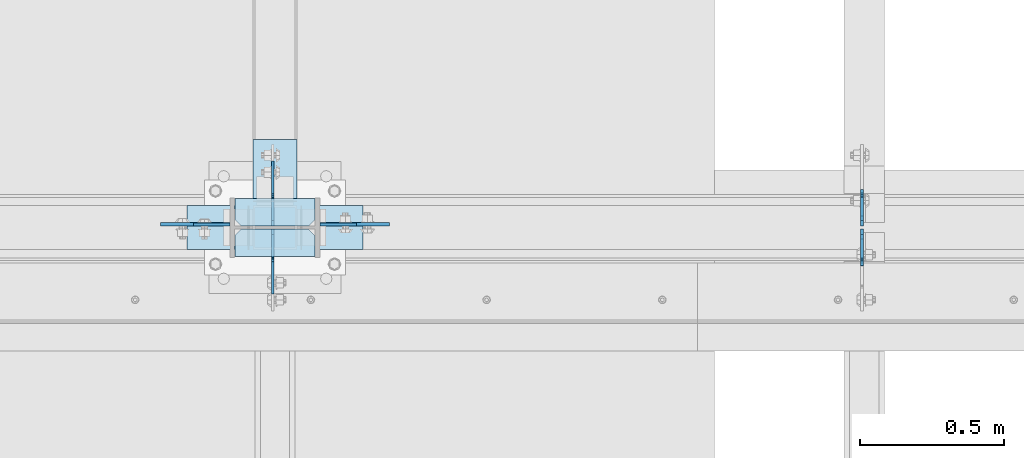
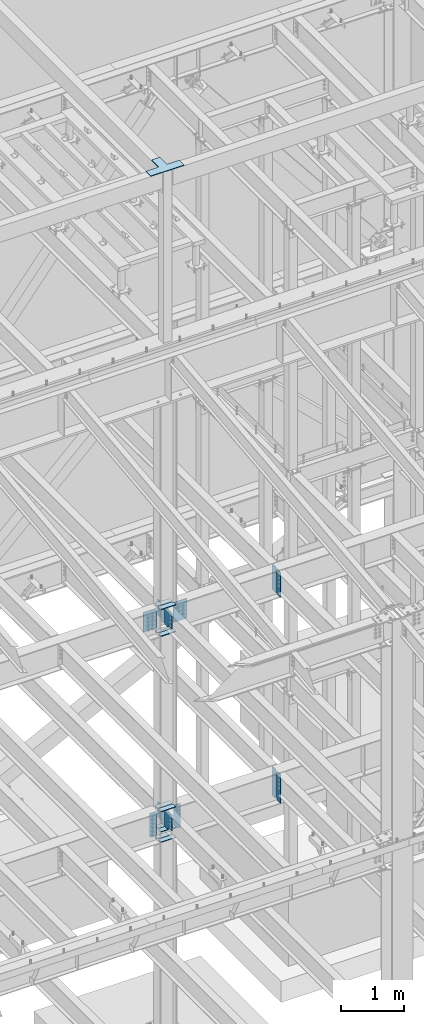
# One storey, part 1064 of 1179: 23 plates, 4 elements without a shape of their own.
"""IFC2X3 building model written with IfcOpenShell, lengths in millimetres."""

from ifc_helpers import new_model, si_unit, frame, origin_with_axes, place, context, subcontext, project, spatial, faceted_brep, material, type_object, element, aggregate, save


model = new_model("IFC2X3")

# Units and contexts
model_context = context("Model", 3, precision=1e-05, world=origin_with_axes())
body_context = subcontext(model_context, "Body", "Model", "MODEL_VIEW")
ifc_project = project(units=[si_unit("LENGTHUNIT", "METRE", prefix="MILLI"), si_unit("AREAUNIT", "SQUARE_METRE"), si_unit("VOLUMEUNIT", "CUBIC_METRE"), si_unit("MASSUNIT", "GRAM", prefix="KILO"), si_unit("TIMEUNIT", "SECOND"), si_unit("PLANEANGLEUNIT", "RADIAN"), si_unit("SOLIDANGLEUNIT", "STERADIAN"), si_unit("THERMODYNAMICTEMPERATUREUNIT", "DEGREE_CELSIUS"), si_unit("LUMINOUSINTENSITYUNIT", "LUMEN")], contexts=[model_context])

# Site, building, storey
site_placement = place(None, origin_with_axes())
site = spatial("IfcSite", under=ifc_project, at=site_placement, CompositionType="ELEMENT")
building_placement = place(site_placement, origin_with_axes())
building = spatial("IfcBuilding", under=site, at=building_placement, Name="Undefined", CompositionType="ELEMENT")
storey_placement = place(building_placement, origin_with_axes())
storey = spatial("IfcBuildingStorey", under=building, at=storey_placement, Name="Undefined", CompositionType="ELEMENT", Elevation=0.0)

# Assembly, plates
assembly_1_placement = place(storey_placement, origin_with_axes())
assembly_1 = element("IfcElementAssembly", 1, at=assembly_1_placement, inside=storey, Name="BEAM", AssemblyPlace="NOTDEFINED", PredefinedType="RIGID_FRAME")
ifc_material_1 = material(Name="STEEL/A36")
plate_type_1 = type_object("IfcPlateType", PredefinedType="NOTDEFINED")
plate_1_placement = place(assembly_1_placement, frame((10317.1620000839, 34396.3625, 7497.7625), z_axis=(0.0, 0.0, 1.0), x_axis=(0.0, 1.0, 0.0)))
plate_1 = element("IfcPlate", 2, at=plate_1_placement, type_object=plate_type_1, material=ifc_material_1, Name="PLATE", context=body_context, shape_type="Brep", body=[
    faceted_brep([(100.012500000004, -4.76250000000073, 498.475), (100.012500000004, -4.76250000000073, 493.712499809265), (100.012500000004, 4.76250000000073, 493.712499809265), (100.012500000004, 4.76250000000073, 498.475), (100.979229922596, -4.76250000000073, 488.852420291219), (100.979229922596, 4.76250000000073, 488.852420291219), (103.732243823069, -4.76250000000073, 484.732243823066), (103.732243823069, 4.76250000000073, 484.732243823066), (107.852420291223, -4.76250000000073, 481.979229922587), (107.852420291223, 4.76250000000073, 481.979229922587), (112.71249980927, -4.76250000000073, 481.0125), (112.71249980927, 4.76250000000073, 481.0125), (127.000007629395, -4.76250000000073, 481.0125), (127.0, 4.76250000000073, 481.0125), (0.0, -4.76250000000073, 479.425006866455), (19.0499992370605, -4.76250000000073, 498.475006103516), (19.0499992370605, 4.76250000000073, 498.475006103516), (0.0, 4.76250000000073, 479.425006866455), (0.0, -4.76250000000073, 19.0499992370605), (0.0, 4.76250000000073, 19.0499992370605), (19.0499992370605, -4.76250000000073, 0.0), (19.0499992370605, 4.76250000000073, 0.0), (127.0, -4.76250000000073, 0.0), (127.0, 4.76250000000073, 0.0)], [[[0, 1, 2, 3]], [[4, 5, 2, 1]], [[6, 7, 5, 4]], [[8, 9, 7, 6]], [[10, 11, 9, 8]], [[12, 13, 11, 10]], [[14, 15, 16, 17]], [[18, 14, 17, 19]], [[20, 18, 19, 21]], [[22, 20, 21, 23]], [[8, 6, 4, 1, 0, 15, 14, 18, 20, 22, 12, 10]], [[16, 15, 0, 3]], [[23, 21, 19, 17, 16, 3, 2, 5, 7, 9, 11, 13]], [[22, 23, 13, 12]]]),
])
plate_2_placement = place(assembly_1_placement, frame((10317.1620000839, 34386.8375, 7497.7625), z_axis=(0.0, 0.0, 1.0), x_axis=(0.0, -1.0, 0.0)))
plate_2 = element("IfcPlate", 3, at=plate_2_placement, type_object=plate_type_1, material=ifc_material_1, Name="PLATE", context=body_context, shape_type="Brep", body=[
    faceted_brep([(100.012500000004, -4.76250000000073, 498.475), (100.012500000004, -4.76250000000073, 493.712499809265), (100.012500000004, 4.76250000000073, 493.712499809265), (100.012500000004, 4.76250000000073, 498.475), (100.979229922596, -4.76250000000073, 488.852420291219), (100.979229922596, 4.76250000000073, 488.852420291219), (103.732243823069, -4.76250000000073, 484.732243823066), (103.732243823069, 4.76250000000073, 484.732243823066), (107.852420291223, -4.76250000000073, 481.979229922587), (107.852420291223, 4.76250000000073, 481.979229922587), (112.71249980927, -4.76250000000073, 481.0125), (112.71249980927, 4.76250000000073, 481.0125), (127.000007629395, -4.76250000000073, 481.0125), (127.0, 4.76250000000073, 481.0125), (0.0, -4.76250000000073, 479.425006866455), (19.0499992370605, -4.76250000000073, 498.475006103516), (19.0499992370605, 4.76250000000073, 498.475006103516), (0.0, 4.76250000000073, 479.425006866455), (0.0, -4.76250000000073, 19.0499992370605), (0.0, 4.76250000000073, 19.0499992370605), (19.0499992370605, -4.76250000000073, 0.0), (19.0499992370605, 4.76250000000073, 0.0), (127.0, -4.76250000000073, 0.0), (127.0, 4.76250000000073, 0.0)], [[[0, 1, 2, 3]], [[4, 5, 2, 1]], [[6, 7, 5, 4]], [[8, 9, 7, 6]], [[10, 11, 9, 8]], [[12, 13, 11, 10]], [[14, 15, 16, 17]], [[18, 14, 17, 19]], [[20, 18, 19, 21]], [[22, 20, 21, 23]], [[8, 6, 4, 1, 0, 15, 14, 18, 20, 22, 12, 10]], [[16, 15, 0, 3]], [[23, 21, 19, 17, 16, 3, 2, 5, 7, 9, 11, 13]], [[22, 23, 13, 12]]]),
])
aggregate(assembly_1, [plate_1, plate_2])

assembly_2_placement = place(storey_placement, origin_with_axes())
assembly_2 = element("IfcElementAssembly", 4, at=assembly_2_placement, inside=storey, Name="COLUMN", AssemblyPlace="NOTDEFINED", PredefinedType="RIGID_FRAME")
plate_3_placement = place(assembly_2_placement, frame((8435.975, 34401.91875, 4051.3), z_axis=(1.0, 0.0, 0.0), x_axis=(0.0, 0.0, -1.0)))
plate_3 = element("IfcPlate", 5, at=plate_3_placement, type_object=plate_type_1, material=ifc_material_1, Name="PLATE", context=body_context, shape_type="Brep", body=[
    faceted_brep([(0.0, -4.76249999999709, 0.0), (0.0, -4.76249999999709, 127.0), (0.0, 4.76249999999709, 127.0), (0.0, 4.76249999999709, 0.0), (457.200012207031, -4.76250000000073, 127.0), (457.200012207031, 4.76250000000073, 127.0), (457.200012207031, -4.76250000000073, 0.0), (457.200012207031, 4.76250000000073, 0.0)], [[[0, 1, 2, 3]], [[1, 4, 5, 2]], [[4, 6, 7, 5]], [[6, 0, 3, 7]], [[5, 7, 3, 2]], [[6, 4, 1, 0]]]),
])
plate_4_placement = place(assembly_2_placement, frame((8124.825, 34401.91875, 4051.3), z_axis=(-1.0, 0.0, 0.0), x_axis=(0.0, 0.0, -1.0)))
plate_4 = element("IfcPlate", 6, at=plate_4_placement, type_object=plate_type_1, material=ifc_material_1, Name="PLATE", context=body_context, shape_type="Brep", body=[
    faceted_brep([(0.0, -4.76249999999709, 0.0), (0.0, -4.76249999999709, 127.0), (0.0, 4.76249999999709, 127.0), (0.0, 4.76249999999709, 0.0), (457.200012207031, -4.76250000000073, 127.0), (457.200012207031, 4.76250000000073, 127.0), (457.200012207031, -4.76250000000073, 0.0), (457.200012207031, 4.76250000000073, 0.0)], [[[0, 1, 2, 3]], [[1, 4, 5, 2]], [[4, 6, 7, 5]], [[6, 0, 3, 7]], [[5, 7, 3, 2]], [[6, 4, 1, 0]]]),
])

assembly_3_placement = place(storey_placement, origin_with_axes())
assembly_3 = element("IfcElementAssembly", 7, at=assembly_3_placement, inside=storey, Name="BEAM", AssemblyPlace="NOTDEFINED", PredefinedType="RIGID_FRAME")
plate_5_placement = place(assembly_3_placement, frame((10317.1620836029, 34397.156250119, 3514.725), z_axis=(0.0, 0.0, 1.0), x_axis=(0.0, 1.0, 0.0)))
plate_5 = element("IfcPlate", 8, at=plate_5_placement, type_object=plate_type_1, material=ifc_material_1, Name="PLATE", context=body_context, shape_type="Brep", body=[
    faceted_brep([(108.743750000001, -4.76250000000073, 571.5), (108.743750000001, -4.76250000000073, 568.324999809266), (108.743750000001, 4.76250000000073, 568.324999809266), (108.743750000001, 4.76250000000073, 571.5), (109.710479922593, -4.76250000000073, 563.46492029122), (109.710479922593, 4.76250000000073, 563.46492029122), (112.463493823067, -4.76250000000073, 559.344743823066), (112.463493823067, 4.76250000000073, 559.344743823066), (116.58367029122, -4.76250000000073, 556.591729922588), (116.58367029122, 4.76250000000073, 556.591729922588), (121.443749809267, -4.76250000000073, 555.625), (121.443749809267, 4.76250000000073, 555.625), (127.000004116075, -4.76250000000073, 555.625), (127.000004116075, 4.76250000000073, 555.625), (0.0, -4.76250000000073, 536.575000762939), (34.9249992370605, -4.76250000000073, 571.5), (34.9249992370605, 4.76250000000073, 571.5), (0.0, 4.76250000000073, 536.575000762939), (0.0, -4.76250000000073, 34.9249999999993), (0.0, 4.76250000000073, 34.9249999999993), (34.9249992370715, -4.76249999996799, 0.0), (34.9249992370678, 4.76250000003347, 0.0), (127.0, -4.76250000000073, 0.0), (127.0, 4.76250000000073, 0.0)], [[[0, 1, 2, 3]], [[4, 5, 2, 1]], [[6, 7, 5, 4]], [[8, 9, 7, 6]], [[10, 11, 9, 8]], [[12, 13, 11, 10]], [[14, 15, 16, 17]], [[18, 14, 17, 19]], [[20, 18, 19, 21]], [[22, 20, 21, 23]], [[8, 6, 4, 1, 0, 15, 14, 18, 20, 22, 12, 10]], [[16, 15, 0, 3]], [[23, 21, 19, 17, 16, 3, 2, 5, 7, 9, 11, 13]], [[22, 23, 13, 12]]]),
])
plate_6_placement = place(assembly_3_placement, frame((10317.1621686935, 34386.04375, 3514.725), z_axis=(0.0, 0.0, 1.0), x_axis=(0.0, -1.0, 0.0)))
plate_6 = element("IfcPlate", 9, at=plate_6_placement, type_object=plate_type_1, material=ifc_material_1, Name="PLATE", context=body_context, shape_type="Brep", body=[
    faceted_brep([(108.743750000001, -4.76250000000073, 571.5), (108.743750000001, -4.76250000000073, 568.324999809266), (108.743750000001, 4.76250000000073, 568.324999809266), (108.743750000001, 4.76250000000073, 571.5), (109.710479922593, -4.76250000000073, 563.46492029122), (109.710479922593, 4.76250000000073, 563.46492029122), (112.463493823067, -4.76250000000073, 559.344743823066), (112.463493823067, 4.76250000000073, 559.344743823066), (116.58367029122, -4.76250000000073, 556.591729922588), (116.58367029122, 4.76250000000073, 556.591729922588), (121.443749809267, -4.76250000000073, 555.625), (121.443749809267, 4.76250000000073, 555.625), (127.000004116075, -4.76250000000073, 555.625), (127.000004116075, 4.76250000000073, 555.625), (0.0, -4.76250000000073, 536.575000762939), (34.9249992370605, -4.76250000000073, 571.5), (34.9249992370605, 4.76250000000073, 571.5), (0.0, 4.76250000000073, 536.575000762939), (0.0, -4.76250000000073, 34.9249999999993), (0.0, 4.76250000000073, 34.9249999999993), (34.9249992370715, -4.76249999996799, 0.0), (34.9249992370678, 4.76250000003347, 0.0), (127.0, -4.76250000000073, 0.0), (127.0, 4.76250000000073, 0.0)], [[[0, 1, 2, 3]], [[4, 5, 2, 1]], [[6, 7, 5, 4]], [[8, 9, 7, 6]], [[10, 11, 9, 8]], [[12, 13, 11, 10]], [[14, 15, 16, 17]], [[18, 14, 17, 19]], [[20, 18, 19, 21]], [[22, 20, 21, 23]], [[8, 6, 4, 1, 0, 15, 14, 18, 20, 22, 12, 10]], [[16, 15, 0, 3]], [[23, 21, 19, 17, 16, 3, 2, 5, 7, 9, 11, 13]], [[22, 23, 13, 12]]]),
])
aggregate(assembly_3, [plate_5, plate_6])

# Plate
ifc_material_2 = material(Name="STEEL/A572-GR.50")
plate_type_2 = type_object("IfcPlateType", PredefinedType="NOTDEFINED")
plate_7_placement = place(assembly_2_placement, frame((8418.5125, 34491.6125, 8005.7625), z_axis=(-1.0, 0.0, 0.0), x_axis=(0.0, -1.0, 0.0)))
plate_7 = element("IfcPlate", 10, at=plate_7_placement, type_object=plate_type_2, material=ifc_material_2, Name="PLATE", context=body_context, shape_type="Brep", body=[
    faceted_brep([(0.0, -7.9375, 0.0), (0.0, -7.9375, 276.225006103516), (0.0, 7.9375, 276.225006103516), (0.0, 7.9375, 0.0), (73.0249996185303, -7.9375, 276.225006103516), (73.0249996185303, 7.9375, 276.225006103516), (95.25, -7.9375, 254.000005722046), (95.25, 7.9375, 254.000005722046), (95.25, -7.9375, 22.2250003814697), (95.25, 7.9375, 22.2250003814697), (73.0249996185303, -7.9375, 0.0), (73.0249996185303, 7.9375, 0.0)], [[[0, 1, 2, 3]], [[1, 4, 5, 2]], [[4, 6, 7, 5]], [[6, 8, 9, 7]], [[8, 10, 11, 9]], [[10, 0, 3, 11]], [[5, 7, 9, 11, 3, 2]], [[10, 8, 6, 4, 1, 0]]]),
])

plate_8_placement = place(assembly_2_placement, frame((8142.2875, 34291.5875, 8005.7625), z_axis=(1.0, 0.0, 0.0), x_axis=(0.0, 1.0, 0.0)))
plate_8 = element("IfcPlate", 11, at=plate_8_placement, type_object=plate_type_2, material=ifc_material_2, Name="PLATE", context=body_context, shape_type="Brep", body=[
    faceted_brep([(0.0, -7.9375, 0.0), (0.0, -7.9375, 276.225006103516), (0.0, 7.9375, 276.225006103516), (0.0, 7.9375, 0.0), (73.0249996185303, -7.9375, 276.225006103516), (73.0249996185303, 7.9375, 276.225006103516), (95.25, -7.9375, 254.000005722046), (95.25, 7.9375, 254.000005722046), (95.25, -7.9375, 22.2250003814697), (95.25, 7.9375, 22.2250003814697), (73.0249996185303, -7.9375, 0.0), (73.0249996185303, 7.9375, 0.0)], [[[0, 1, 2, 3]], [[1, 4, 5, 2]], [[4, 6, 7, 5]], [[6, 8, 9, 7]], [[8, 10, 11, 9]], [[10, 0, 3, 11]], [[5, 7, 9, 11, 3, 2]], [[10, 8, 6, 4, 1, 0]]]),
])

plate_9_placement = place(assembly_2_placement, frame((8418.5125, 34491.6125, 7488.2375), z_axis=(-1.0, 0.0, 0.0), x_axis=(0.0, -1.0, 0.0)))
plate_9 = element("IfcPlate", 12, at=plate_9_placement, type_object=plate_type_2, material=ifc_material_2, Name="PLATE", context=body_context, shape_type="Brep", body=[
    faceted_brep([(0.0, -7.9375, 0.0), (0.0, -7.9375, 276.225006103516), (0.0, 7.9375, 276.225006103516), (0.0, 7.9375, 0.0), (73.0249996185303, -7.9375, 276.225006103516), (73.0249996185303, 7.9375, 276.225006103516), (95.25, -7.9375, 254.000005722046), (95.25, 7.9375, 254.000005722046), (95.25, -7.9375, 22.2250003814697), (95.25, 7.9375, 22.2250003814697), (73.0249996185303, -7.9375, 0.0), (73.0249996185303, 7.9375, 0.0)], [[[0, 1, 2, 3]], [[1, 4, 5, 2]], [[4, 6, 7, 5]], [[6, 8, 9, 7]], [[8, 10, 11, 9]], [[10, 0, 3, 11]], [[5, 7, 9, 11, 3, 2]], [[10, 8, 6, 4, 1, 0]]]),
])

plate_10_placement = place(assembly_2_placement, frame((8418.5125, 34386.8375, 7488.2375), z_axis=(-1.0, 0.0, 0.0), x_axis=(0.0, -1.0, 0.0)))
plate_10 = element("IfcPlate", 13, at=plate_10_placement, type_object=plate_type_2, material=ifc_material_2, Name="PLATE", context=body_context, shape_type="Brep", body=[
    faceted_brep([(0.0, -7.9375, 22.2250003814697), (0.0, -7.9375, 254.000005722046), (0.0, 7.9375, 254.000005722046), (0.0, 7.9375, 22.2250003814697), (22.2250003814697, -7.9375, 276.225006103516), (22.2250003814697, 7.9375, 276.225006103516), (95.25, -7.9375, 276.225006103516), (95.25, 7.9375, 276.225006103516), (95.25, -7.9375, 0.0), (95.25, 7.9375, 0.0), (22.2250003814697, -7.9375, 0.0), (22.2250003814697, 7.9375, 0.0)], [[[0, 1, 2, 3]], [[1, 4, 5, 2]], [[4, 6, 7, 5]], [[6, 8, 9, 7]], [[8, 10, 11, 9]], [[10, 0, 3, 11]], [[5, 7, 9, 11, 3, 2]], [[10, 8, 6, 4, 1, 0]]]),
])

plate_type_3 = type_object("IfcPlateType", PredefinedType="NOTDEFINED")
plate_11_placement = place(assembly_2_placement, frame((8418.5125, 34386.8375, 3505.2), z_axis=(-1.0, 0.0, 0.0), x_axis=(0.0, -1.0, 0.0)))
plate_11 = element("IfcPlate", 14, at=plate_11_placement, type_object=plate_type_3, material=ifc_material_1, Name="PLATE", context=body_context, shape_type="Brep", body=[
    faceted_brep([(0.0, -6.34999999999854, 22.2250003814697), (0.0, -6.35000000000036, 254.000005722046), (0.0, 6.35000000000036, 254.000005722046), (0.0, 6.34999999999854, 22.2250003814697), (22.2250003814697, -6.35000000000036, 276.225006103516), (22.2250003814697, 6.35000000000036, 276.225006103516), (95.25, -6.35000000000036, 276.225006103516), (95.25, 6.35000000000036, 276.225006103516), (95.25, -6.34999999999309, 1.81898940354586e-12), (95.25, 6.34999999999854, -1.81898940354586e-12), (22.2250003814697, -6.34999999999854, 0.0), (22.2250003814697, 6.34999999999854, 0.0)], [[[0, 1, 2, 3]], [[1, 4, 5, 2]], [[4, 6, 7, 5]], [[6, 8, 9, 7]], [[8, 10, 11, 9]], [[10, 0, 3, 11]], [[5, 7, 9, 11, 3, 2]], [[10, 8, 6, 4, 1, 0]]]),
])

plate_12_placement = place(assembly_2_placement, frame((8418.5125, 34491.6125, 3505.2), z_axis=(-1.0, 0.0, 0.0), x_axis=(0.0, -1.0, 0.0)))
plate_12 = element("IfcPlate", 15, at=plate_12_placement, type_object=plate_type_3, material=ifc_material_1, Name="PLATE", context=body_context, shape_type="Brep", body=[
    faceted_brep([(0.0, -6.34999999999854, 0.0), (0.0, -6.35000000000036, 276.225006103516), (0.0, 6.35000000000036, 276.225006103516), (0.0, 6.34999999999854, 0.0), (73.0249996185303, -6.35000000000036, 276.225006103516), (73.0249996185303, 6.35000000000036, 276.225006103516), (95.25, -6.35000000000036, 254.000005722046), (95.25, 6.35000000000036, 254.000005722046), (95.25, -6.35000000000036, 22.2250003814697), (95.25, 6.35000000000036, 22.2250003814697), (73.0249999999996, -6.34999999999854, 0.0), (73.0249999999996, 6.34999999999854, 0.0)], [[[0, 1, 2, 3]], [[1, 4, 5, 2]], [[4, 6, 7, 5]], [[6, 8, 9, 7]], [[8, 10, 11, 9]], [[10, 0, 3, 11]], [[5, 7, 9, 11, 3, 2]], [[10, 8, 6, 4, 1, 0]]]),
])

plate_13_placement = place(assembly_2_placement, frame((8142.2875, 34291.5875, 3705.225), z_axis=(1.0, 0.0, 0.0), x_axis=(0.0, 1.0, 0.0)))
plate_13 = element("IfcPlate", 16, at=plate_13_placement, type_object=plate_type_3, material=ifc_material_1, Name="PLATE", context=body_context, shape_type="Brep", body=[
    faceted_brep([(0.0, -6.34999999999854, 0.0), (0.0, -6.35000000000036, 276.225006103516), (0.0, 6.35000000000036, 276.225006103516), (0.0, 6.34999999999854, 0.0), (73.0249996185303, -6.35000000000036, 276.225006103516), (73.0249996185303, 6.35000000000036, 276.225006103516), (95.25, -6.35000000000036, 254.000005722046), (95.25, 6.35000000000036, 254.000005722046), (95.25, -6.35000000000036, 22.2250003814697), (95.25, 6.35000000000036, 22.2250003814697), (73.0249999999996, -6.34999999999854, 0.0), (73.0249999999996, 6.34999999999854, 0.0)], [[[0, 1, 2, 3]], [[1, 4, 5, 2]], [[4, 6, 7, 5]], [[6, 8, 9, 7]], [[8, 10, 11, 9]], [[10, 0, 3, 11]], [[5, 7, 9, 11, 3, 2]], [[10, 8, 6, 4, 1, 0]]]),
])

plate_14_placement = place(assembly_2_placement, frame((8142.2875, 34291.5875, 4095.75), z_axis=(1.0, 0.0, 0.0), x_axis=(0.0, 1.0, 0.0)))
plate_14 = element("IfcPlate", 17, at=plate_14_placement, type_object=plate_type_3, material=ifc_material_1, Name="PLATE", context=body_context, shape_type="Brep", body=[
    faceted_brep([(0.0, -6.34999999999854, 0.0), (0.0, -6.35000000000036, 276.225006103516), (0.0, 6.35000000000036, 276.225006103516), (0.0, 6.34999999999854, 0.0), (73.0249996185303, -6.35000000000036, 276.225006103516), (73.0249996185303, 6.35000000000036, 276.225006103516), (95.25, -6.35000000000036, 254.000005722046), (95.25, 6.35000000000036, 254.000005722046), (95.25, -6.35000000000036, 22.2250003814697), (95.25, 6.35000000000036, 22.2250003814697), (73.0249999999996, -6.34999999999854, 0.0), (73.0249999999996, 6.34999999999854, 0.0)], [[[0, 1, 2, 3]], [[1, 4, 5, 2]], [[4, 6, 7, 5]], [[6, 8, 9, 7]], [[8, 10, 11, 9]], [[10, 0, 3, 11]], [[5, 7, 9, 11, 3, 2]], [[10, 8, 6, 4, 1, 0]]]),
])

plate_15_placement = place(assembly_2_placement, frame((8418.5125, 34491.6125, 3705.22499999964), z_axis=(-1.0, 0.0, 0.0), x_axis=(0.0, -1.0, 0.0)))
plate_15 = element("IfcPlate", 18, at=plate_15_placement, type_object=plate_type_3, material=ifc_material_1, Name="PLATE", context=body_context, shape_type="Brep", body=[
    faceted_brep([(0.0, -6.34999999999854, 0.0), (0.0, -6.35000000000036, 276.225006103516), (0.0, 6.35000000000036, 276.225006103516), (0.0, 6.34999999999854, 0.0), (73.0249996185303, -6.35000000000036, 276.225006103516), (73.0249996185303, 6.35000000000036, 276.225006103516), (95.25, -6.35000000000036, 254.000005722046), (95.25, 6.35000000000036, 254.000005722046), (95.25, -6.35000000000036, 22.2250003814697), (95.25, 6.35000000000036, 22.2250003814697), (73.0249999999996, -6.34999999999854, 0.0), (73.0249999999996, 6.34999999999854, 0.0)], [[[0, 1, 2, 3]], [[1, 4, 5, 2]], [[4, 6, 7, 5]], [[6, 8, 9, 7]], [[8, 10, 11, 9]], [[10, 0, 3, 11]], [[5, 7, 9, 11, 3, 2]], [[10, 8, 6, 4, 1, 0]]]),
])

plate_16_placement = place(assembly_2_placement, frame((8418.5125, 34491.6125, 4095.74999999964), z_axis=(-1.0, 0.0, 0.0), x_axis=(0.0, -1.0, 0.0)))
plate_16 = element("IfcPlate", 19, at=plate_16_placement, type_object=plate_type_3, material=ifc_material_1, Name="PLATE", context=body_context, shape_type="Brep", body=[
    faceted_brep([(0.0, -6.34999999999854, 0.0), (0.0, -6.35000000000036, 276.225006103516), (0.0, 6.35000000000036, 276.225006103516), (0.0, 6.34999999999854, 0.0), (73.0249996185303, -6.35000000000036, 276.225006103516), (73.0249996185303, 6.35000000000036, 276.225006103516), (95.25, -6.35000000000036, 254.000005722046), (95.25, 6.35000000000036, 254.000005722046), (95.25, -6.35000000000036, 22.2250003814697), (95.25, 6.35000000000036, 22.2250003814697), (73.0249999999996, -6.34999999999854, 0.0), (73.0249999999996, 6.34999999999854, 0.0)], [[[0, 1, 2, 3]], [[1, 4, 5, 2]], [[4, 6, 7, 5]], [[6, 8, 9, 7]], [[8, 10, 11, 9]], [[10, 0, 3, 11]], [[5, 7, 9, 11, 3, 2]], [[10, 8, 6, 4, 1, 0]]]),
])

# Assembly, plate
assembly_4_placement = place(storey_placement, origin_with_axes())
assembly_4 = element("IfcElementAssembly", 20, at=assembly_4_placement, inside=storey, Name="PLATE", AssemblyPlace="NOTDEFINED", PredefinedType="RIGID_FRAME")
plate_type_4 = type_object("IfcPlateType", PredefinedType="NOTDEFINED")
plate_17_placement = place(assembly_4_placement, frame((8585.20000002976, 34467.8, 16433.8), z_axis=(0.0, -1.0, 0.0), x_axis=(-1.0, 0.0, 0.0)))
plate_17 = element("IfcPlate", 21, at=plate_17_placement, type_object=plate_type_4, material=ifc_material_1, Name="PLATE", context=body_context, shape_type="Brep", body=[
    faceted_brep([(0.0, -6.34999999999854, 0.0), (0.0, -6.34999999999854, 152.400000000001), (0.0, 6.34999999999854, 152.400000000001), (0.0, 6.34999999999854, 0.0), (609.600000000002, -6.34999999999854, 152.399999999994), (609.600000000002, 6.34999999999854, 152.399999999994), (609.600000000002, -6.34999999999854, 0.0), (609.600000000002, 6.34999999999854, 0.0), (381.000000000002, -6.34999999999854, 0.0), (381.000000000002, 6.34999999999854, 0.0), (381.000000000002, -6.34999999999854, -228.599999999999), (381.000000000002, 6.34999999999854, -228.599999999999), (228.600000000002, -6.34999999999854, -228.599999999999), (228.600000000002, 6.34999999999854, -228.599999999999), (228.600000000002, -6.34999999999854, 0.0), (228.600000000002, 6.34999999999854, 0.0)], [[[0, 1, 2, 3]], [[1, 4, 5, 2]], [[4, 6, 7, 5]], [[6, 8, 9, 7]], [[8, 10, 11, 9]], [[10, 12, 13, 11]], [[12, 14, 15, 13]], [[14, 0, 3, 15]], [[5, 7, 9, 11, 13, 15, 3, 2]], [[14, 12, 10, 8, 6, 4, 1, 0]]]),
])
aggregate(assembly_4, [plate_17])

# Plate
plate_type_5 = type_object("IfcPlateType", PredefinedType="NOTDEFINED")
plate_18_placement = place(assembly_2_placement, frame((8272.46200008392, 34386.8375, 7645.40000146665), z_axis=(0.0, -0.707106781186506, 0.707106781186589), x_axis=(0.0, -0.70710678118659, -0.707106781186505)))
plate_18 = element("IfcPlate", 22, at=plate_18_placement, type_object=plate_type_5, material=ifc_material_2, Name="PLATE", context=body_context, shape_type="Brep", body=[
    faceted_brep([(0.0, -4.76249999999709, 0.0), (-235.73172493462, -4.76250000000073, 235.731721421063), (-235.73172493462, 4.76250000000073, 235.731721421063), (0.0, 4.76249999999709, 0.0), (-235.731724934682, -4.76250000000073, 262.672489583438), (-235.731724934682, 4.76250000000073, 262.672489583438), (-179.605124832691, -4.76250000000073, 318.799089388474), (-179.605124832691, 4.76250000000073, 318.799089388474), (-172.394815745483, -4.76250000000073, 313.981314961322), (-172.394815745483, 4.76250000000073, 313.981314961322), (-163.889676302584, -4.76250000000073, 312.28953760572), (-163.889676302584, 4.76250000000073, 312.28953760572), (-155.3845368849, -4.76250000000073, 313.981315088055), (-155.3845368849, 4.76250000000073, 313.981315088055), (-148.174227869498, -4.76250000000073, 318.79908962264), (-148.174227869498, 4.76250000000073, 318.79908962264), (-74.0871122469689, -4.76250000000073, 392.886206349045), (-74.0871122469689, 4.76250000000073, 392.886206349045), (141.439036264685, -4.76250000000073, 177.360061049792), (141.439036264685, 4.76250000000073, 177.360061049792), (69.5969841162332, -4.76250000000073, 105.518007830909), (69.5969841162332, 4.76250000000073, 105.518007830909), (64.0909563766836, -4.76250000000073, 97.2776548535985), (64.0909563766836, 4.76250000000073, 97.2776548535985), (62.1574966039516, -4.76250000000073, 87.5574958031284), (62.1574966039516, 4.76250000000073, 87.5574958031284), (64.0909565215625, -4.76250000000073, 77.8373367814602), (64.0909565215625, 4.76250000000073, 77.8373367814602), (69.5969843839302, -4.76250000000073, 69.5969838861893), (69.5969843839302, 4.76250000000073, 69.5969838861893), (83.0673691195552, -4.76249999999709, 56.126600756339), (83.0673691195552, 4.76249999999709, 56.126600756339), (26.9407683631525, -4.76249999999709, -6.18456397205591e-11), (26.9407683631525, 4.76249999999709, -6.18456397205591e-11)], [[[0, 1, 2, 3]], [[1, 4, 5, 2]], [[4, 6, 7, 5]], [[6, 8, 9, 7]], [[8, 10, 11, 9]], [[10, 12, 13, 11]], [[12, 14, 15, 13]], [[14, 16, 17, 15]], [[16, 18, 19, 17]], [[18, 20, 21, 19]], [[20, 22, 23, 21]], [[22, 24, 25, 23]], [[24, 26, 27, 25]], [[26, 28, 29, 27]], [[28, 30, 31, 29]], [[30, 32, 33, 31]], [[32, 0, 3, 33]], [[5, 7, 9, 11, 13, 15, 17, 19, 21, 23, 25, 27, 29, 31, 33, 3, 2]], [[32, 30, 28, 26, 24, 22, 20, 18, 16, 14, 12, 10, 8, 6, 4, 1, 0]]]),
])

plate_19_placement = place(assembly_2_placement, frame((8272.46200008392, 34396.3625, 7645.40000146665), z_axis=(0.0, 0.707106781186542, 0.707106781186553), x_axis=(0.0, 0.707106781186553, -0.707106781186542)))
plate_19 = element("IfcPlate", 23, at=plate_19_placement, type_object=plate_type_5, material=ifc_material_2, Name="PLATE", context=body_context, shape_type="Brep", body=[
    faceted_brep([(0.0, -4.76249999999709, 0.0), (-235.73172493462, -4.76250000000073, 235.731721421063), (-235.73172493462, 4.76250000000073, 235.731721421063), (0.0, 4.76249999999709, 0.0), (-235.731724934682, -4.76250000000073, 262.672489583438), (-235.731724934682, 4.76250000000073, 262.672489583438), (-179.605124832691, -4.76250000000073, 318.799089388474), (-179.605124832691, 4.76250000000073, 318.799089388474), (-172.394815745483, -4.76250000000073, 313.981314961322), (-172.394815745483, 4.76250000000073, 313.981314961322), (-163.889676302584, -4.76250000000073, 312.28953760572), (-163.889676302584, 4.76250000000073, 312.28953760572), (-155.3845368849, -4.76250000000073, 313.981315088055), (-155.3845368849, 4.76250000000073, 313.981315088055), (-148.174227869498, -4.76250000000073, 318.79908962264), (-148.174227869498, 4.76250000000073, 318.79908962264), (-74.0871122469689, -4.76250000000073, 392.886206349045), (-74.0871122469689, 4.76250000000073, 392.886206349045), (141.439036264685, -4.76250000000073, 177.360061049792), (141.439036264685, 4.76250000000073, 177.360061049792), (69.5969841162332, -4.76250000000073, 105.518007830909), (69.5969841162332, 4.76250000000073, 105.518007830909), (64.0909563766836, -4.76250000000073, 97.2776548535985), (64.0909563766836, 4.76250000000073, 97.2776548535985), (62.1574966039516, -4.76250000000073, 87.5574958031284), (62.1574966039516, 4.76250000000073, 87.5574958031284), (64.0909565215625, -4.76250000000073, 77.8373367814602), (64.0909565215625, 4.76250000000073, 77.8373367814602), (69.5969843839302, -4.76250000000073, 69.5969838861893), (69.5969843839302, 4.76250000000073, 69.5969838861893), (83.0673691195552, -4.76249999999709, 56.126600756339), (83.0673691195552, 4.76249999999709, 56.126600756339), (26.9407683631525, -4.76249999999709, -6.18456397205591e-11), (26.9407683631525, 4.76249999999709, -6.18456397205591e-11)], [[[0, 1, 2, 3]], [[1, 4, 5, 2]], [[4, 6, 7, 5]], [[6, 8, 9, 7]], [[8, 10, 11, 9]], [[10, 12, 13, 11]], [[12, 14, 15, 13]], [[14, 16, 17, 15]], [[16, 18, 19, 17]], [[18, 20, 21, 19]], [[20, 22, 23, 21]], [[22, 24, 25, 23]], [[24, 26, 27, 25]], [[26, 28, 29, 27]], [[28, 30, 31, 29]], [[30, 32, 33, 31]], [[32, 0, 3, 33]], [[5, 7, 9, 11, 13, 15, 17, 19, 21, 23, 25, 27, 29, 31, 33, 3, 2]], [[32, 30, 28, 26, 24, 22, 20, 18, 16, 14, 12, 10, 8, 6, 4, 1, 0]]]),
])

plate_20_placement = place(assembly_2_placement, frame((8272.46200008392, 34386.8375, 3730.62500146665), z_axis=(0.0, -0.707106781186506, 0.707106781186589), x_axis=(0.0, -0.70710678118659, -0.707106781186505)))
plate_20 = element("IfcPlate", 24, at=plate_20_placement, type_object=plate_type_5, material=ifc_material_1, Name="PLATE", context=body_context, shape_type="Brep", body=[
    faceted_brep([(0.0, -4.76249999999709, 0.0), (-240.221851238686, -4.76249999999709, 240.221851238675), (-240.221851238686, 4.76249999999709, 240.221851238675), (0.0, 4.76249999999709, 0.0), (-240.221851238757, -4.76249999999709, 267.162619601822), (-240.221851238757, 4.76249999999709, 267.162619601822), (-184.095246317615, -4.76250000000073, 323.289216042809), (-184.095246317615, 4.76250000000073, 323.289216042809), (-175.854893630505, -4.76250000000073, 317.783188345089), (-175.854893630505, 4.76250000000073, 317.783188345089), (-166.134734884679, -4.76250000000073, 315.84972839669), (-166.134734884679, 4.76250000000073, 315.84972839669), (-156.414576056737, -4.76250000000073, 317.783187932182), (-156.414576056737, 4.76250000000073, 317.783187932182), (-148.17422313576, -4.76250000000073, 323.289215279867), (-148.17422313576, 4.76250000000073, 323.289215279867), (-76.3321762094201, -4.76250000000073, 395.131256102708), (-76.3321762094201, 4.76250000000073, 395.131256102708), (139.193969726119, -4.76250000000073, 179.605117797448), (139.193969726119, 4.76250000000073, 179.605117797448), (67.3519197480127, -4.76250000000073, 107.763070871089), (67.3519197480127, 4.76250000000073, 107.763070871089), (61.8458917204443, -4.76250000000073, 99.5227179271387), (61.8458917204443, 4.76250000000073, 99.5227179271387), (59.9124317204551, -4.76250000000073, 89.8025587869961), (59.9124317204551, 4.76250000000073, 89.8025587869961), (61.8458915140363, -4.76250000000073, 80.0823996057879), (61.8458915140363, 4.76250000000073, 80.0823996057879), (67.3519193666289, -4.76250000000073, 71.8420465448944), (67.3519193666289, 4.76250000000073, 71.8420465448944), (83.0673691195552, -4.76249999999709, 56.126600756339), (83.0673691195552, 4.76249999999709, 56.126600756339), (26.9407683631525, -4.76249999999709, -6.18456397205591e-11), (26.9407683631525, 4.76249999999709, -6.18456397205591e-11)], [[[0, 1, 2, 3]], [[1, 4, 5, 2]], [[4, 6, 7, 5]], [[6, 8, 9, 7]], [[8, 10, 11, 9]], [[10, 12, 13, 11]], [[12, 14, 15, 13]], [[14, 16, 17, 15]], [[16, 18, 19, 17]], [[18, 20, 21, 19]], [[20, 22, 23, 21]], [[22, 24, 25, 23]], [[24, 26, 27, 25]], [[26, 28, 29, 27]], [[28, 30, 31, 29]], [[30, 32, 33, 31]], [[32, 0, 3, 33]], [[5, 7, 9, 11, 13, 15, 17, 19, 21, 23, 25, 27, 29, 31, 33, 3, 2]], [[32, 30, 28, 26, 24, 22, 20, 18, 16, 14, 12, 10, 8, 6, 4, 1, 0]]]),
])

plate_21_placement = place(assembly_2_placement, frame((8272.46191505281, 34396.3625003175, 3730.62500146665), z_axis=(0.0, 0.707106781186542, 0.707106781186553), x_axis=(0.0, 0.707106781186553, -0.707106781186542)))
plate_21 = element("IfcPlate", 25, at=plate_21_placement, type_object=plate_type_5, material=ifc_material_1, Name="PLATE", context=body_context, shape_type="Brep", body=[
    faceted_brep([(0.0, -4.76249999999709, 0.0), (-240.221851238686, -4.76249999999709, 240.221851238675), (-240.221851238686, 4.76249999999709, 240.221851238675), (0.0, 4.76249999999709, 0.0), (-240.221851238757, -4.76249999999709, 267.162619601822), (-240.221851238757, 4.76249999999709, 267.162619601822), (-184.095246317615, -4.76250000000073, 323.289216042809), (-184.095246317615, 4.76250000000073, 323.289216042809), (-175.854893630505, -4.76250000000073, 317.783188345089), (-175.854893630505, 4.76250000000073, 317.783188345089), (-166.134734884679, -4.76250000000073, 315.84972839669), (-166.134734884679, 4.76250000000073, 315.84972839669), (-156.414576056737, -4.76250000000073, 317.783187932182), (-156.414576056737, 4.76250000000073, 317.783187932182), (-148.17422313576, -4.76250000000073, 323.289215279867), (-148.17422313576, 4.76250000000073, 323.289215279867), (-76.3321762094201, -4.76250000000073, 395.131256102708), (-76.3321762094201, 4.76250000000073, 395.131256102708), (139.193969726119, -4.76250000000073, 179.605117797448), (139.193969726119, 4.76250000000073, 179.605117797448), (67.3519197480127, -4.76250000000073, 107.763070871089), (67.3519197480127, 4.76250000000073, 107.763070871089), (61.8458917204443, -4.76250000000073, 99.5227179271387), (61.8458917204443, 4.76250000000073, 99.5227179271387), (59.9124317204551, -4.76250000000073, 89.8025587869961), (59.9124317204551, 4.76250000000073, 89.8025587869961), (61.8458915140363, -4.76250000000073, 80.0823996057879), (61.8458915140363, 4.76250000000073, 80.0823996057879), (67.3519193666289, -4.76250000000073, 71.8420465448944), (67.3519193666289, 4.76250000000073, 71.8420465448944), (83.0673691195552, -4.76249999999709, 56.126600756339), (83.0673691195552, 4.76249999999709, 56.126600756339), (26.9407683631525, -4.76249999999709, -6.18456397205591e-11), (26.9407683631525, 4.76249999999709, -6.18456397205591e-11)], [[[0, 1, 2, 3]], [[1, 4, 5, 2]], [[4, 6, 7, 5]], [[6, 8, 9, 7]], [[8, 10, 11, 9]], [[10, 12, 13, 11]], [[12, 14, 15, 13]], [[14, 16, 17, 15]], [[16, 18, 19, 17]], [[18, 20, 21, 19]], [[20, 22, 23, 21]], [[22, 24, 25, 23]], [[24, 26, 27, 25]], [[26, 28, 29, 27]], [[28, 30, 31, 29]], [[30, 32, 33, 31]], [[32, 0, 3, 33]], [[5, 7, 9, 11, 13, 15, 17, 19, 21, 23, 25, 27, 29, 31, 33, 3, 2]], [[32, 30, 28, 26, 24, 22, 20, 18, 16, 14, 12, 10, 8, 6, 4, 1, 0]]]),
])

plate_type_6 = type_object("IfcPlateType", PredefinedType="NOTDEFINED")
plate_22_placement = place(assembly_2_placement, frame((8435.975, 34402.7125, 7975.6), z_axis=(1.0, 0.0, 0.0), x_axis=(0.0, 0.0, -1.0)))
plate_22 = element("IfcPlate", 26, at=plate_22_placement, type_object=plate_type_6, material=ifc_material_2, Name="PLATE", context=body_context, shape_type="Brep", body=[
    faceted_brep([(0.0, -6.34999999999854, 0.0), (0.0, -6.34999999999854, 241.300003051758), (0.0, 6.34999999999854, 241.300003051758), (0.0, 6.34999999999854, 0.0), (381.0, -6.34999999999854, 241.300003051758), (381.0, 6.34999999999854, 241.300003051758), (381.000000000002, -6.34999999999854, 0.0), (381.000000000002, 6.34999999999854, 0.0)], [[[0, 1, 2, 3]], [[1, 4, 5, 2]], [[4, 6, 7, 5]], [[6, 0, 3, 7]], [[5, 7, 3, 2]], [[6, 4, 1, 0]]]),
])

plate_23_placement = place(assembly_2_placement, frame((8124.825, 34402.7125, 7975.6), z_axis=(-1.0, 0.0, 0.0), x_axis=(0.0, 0.0, -1.0)))
plate_23 = element("IfcPlate", 27, at=plate_23_placement, type_object=plate_type_6, material=ifc_material_2, Name="PLATE", context=body_context, shape_type="Brep", body=[
    faceted_brep([(0.0, -6.34999999999854, 0.0), (0.0, -6.34999999999854, 241.300003051758), (0.0, 6.34999999999854, 241.300003051758), (0.0, 6.34999999999854, 0.0), (381.0, -6.34999999999854, 241.300003051758), (381.0, 6.34999999999854, 241.300003051758), (381.000000000002, -6.34999999999854, 0.0), (381.000000000002, 6.34999999999854, 0.0)], [[[0, 1, 2, 3]], [[1, 4, 5, 2]], [[4, 6, 7, 5]], [[6, 0, 3, 7]], [[5, 7, 3, 2]], [[6, 4, 1, 0]]]),
])

aggregate(assembly_2, [plate_7, plate_8, plate_9, plate_22, plate_10, plate_23, plate_18, plate_19, plate_3, plate_11, plate_12, plate_4, plate_13, plate_14, plate_20, plate_15, plate_16, plate_21])

save(model, "model.ifc")
